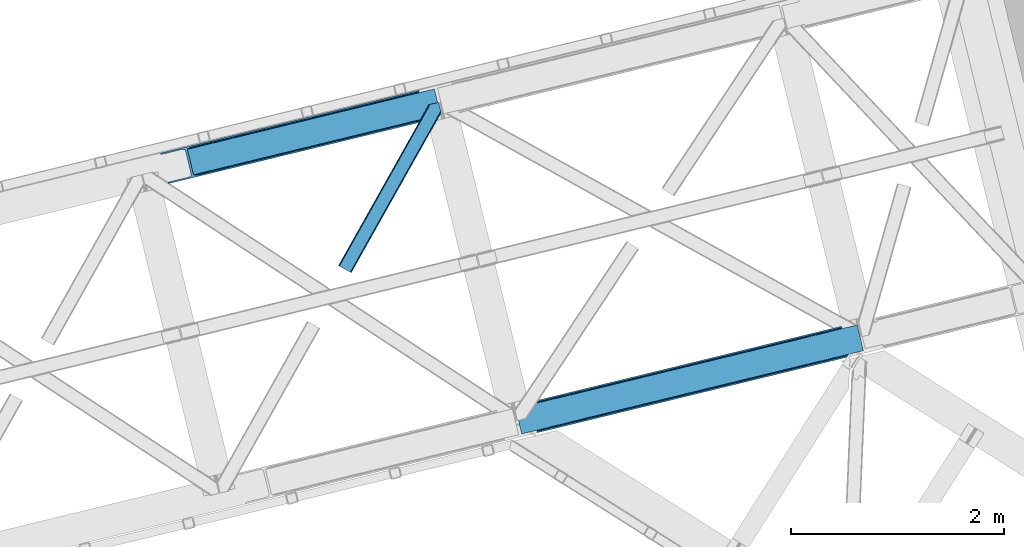
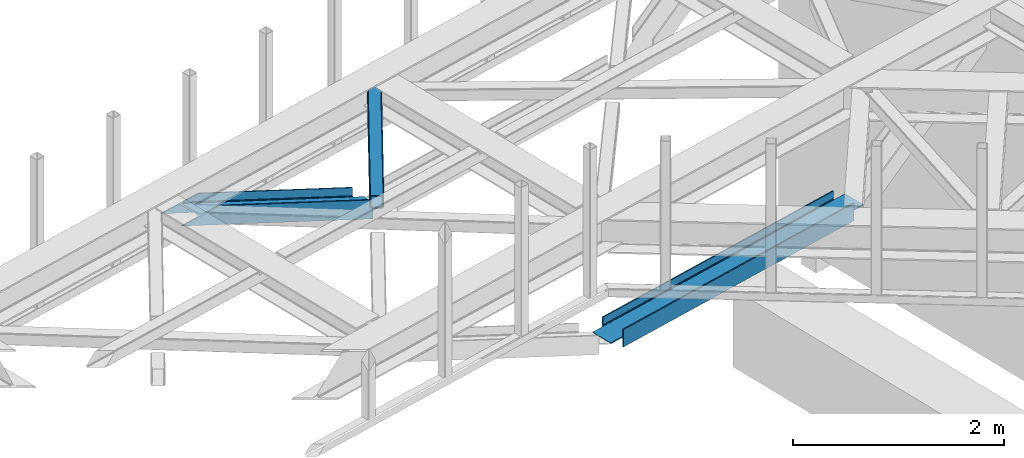
# One storey, part 57 of 67: 3 members.
"""IFC4 building model written with IfcOpenShell, lengths in millimetres."""

import ifcopenshell
import ifcopenshell.guid

model = None  # the IFC model being written
_history = None  # IfcOwnerHistory: only IFC2X3 demands one
_inside = {}  # id of a spatial element -> (the spatial element, [elements in it])
_under = {}  # id of a project, library or spatial element -> (it, [spatial elements below it])
_declared = {}  # id of a project -> (the project, [libraries it declares])
_typed = {}  # id of a type object -> (the type object, [elements of that type])
_made_of = {}  # id of a material, layer set ... -> (it, [elements and type objects made of it])


def new_model(schema):
    """Start an empty IFC model of exactly this schema.

    Asked for "IFC4X3", IfcOpenShell would pick the latest addendum, in which some entities
    have other attributes; the version numbers below select the first issue.
    IFC2X3 requires an IfcOwnerHistory on every rooted entity: one is made here for all.
    """
    global model, _history
    if schema == "IFC4X3":
        model = ifcopenshell.file(schema_version=(4, 3, 0, 0))
    else:
        model = ifcopenshell.file(schema=schema)
    _inside.clear()
    _under.clear()
    _declared.clear()
    _typed.clear()
    _made_of.clear()
    _history = None
    if model.schema == "IFC2X3":
        org = make("IfcOrganization", Name="unknown")
        user = make(
            "IfcPersonAndOrganization",
            ThePerson=make("IfcPerson", FamilyName="unknown"),
            TheOrganization=org,
        )
        app = make(
            "IfcApplication",
            ApplicationDeveloper=org,
            Version="unknown",
            ApplicationFullName="unknown",
            ApplicationIdentifier="unknown",
        )
        _history = make(
            "IfcOwnerHistory",
            OwningUser=user,
            OwningApplication=app,
            ChangeAction="ADDED",
            CreationDate=0,
        )
    return model


def make(cls, **values):
    """One entity of the class cls with the attributes given. An attribute that is None is left unset."""
    return model.create_entity(
        cls, **{name: value for name, value in values.items() if value is not None}
    )


def entity(cls, *values):
    """Any entity or typed value of the class cls, its attributes in the order of the schema. None: left unset."""
    e = model.create_entity(cls)
    for i, value in enumerate(values):
        if value is not None:
            e[i] = value
    return e


def rooted(cls, **values):
    """An entity with a GlobalId (a new one), such as an element, a storey or a relation."""
    return make(cls, GlobalId=ifcopenshell.guid.new(), OwnerHistory=_history, **values)


def si_unit(unit_type, name, prefix=None):
    """IfcSIUnit, for example si_unit("LENGTHUNIT", "METRE", prefix="MILLI")."""
    return make("IfcSIUnit", UnitType=unit_type, Prefix=prefix, Name=name)


def converted_unit(unit_type, name, factor, base, dimensions=None, offset=None):
    """IfcConversionBasedUnit, such as the inch: factor (a typed value) times the base unit."""
    return make(
        "IfcConversionBasedUnit"
        if offset is None
        else "IfcConversionBasedUnitWithOffset",
        ConversionOffset=offset,
        Dimensions=None
        if dimensions is None
        else entity("IfcDimensionalExponents", *dimensions),
        UnitType=unit_type,
        Name=name,
        ConversionFactor=make(
            "IfcMeasureWithUnit", ValueComponent=factor, UnitComponent=base
        ),
    )


def derived_unit(unit_type, elements):
    """IfcDerivedUnit: a product of units, each with its exponent."""
    return make(
        "IfcDerivedUnit",
        Elements=[
            make("IfcDerivedUnitElement", Unit=unit, Exponent=power)
            for unit, power in elements
        ],
        UnitType=unit_type,
    )


def assignment(units):
    """IfcUnitAssignment: the units of a project."""
    return None if units is None else make("IfcUnitAssignment", Units=units)


def point(xyz):
    """IfcCartesianPoint."""
    return None if xyz is None else make("IfcCartesianPoint", Coordinates=xyz)


def direction(xyz):
    """IfcDirection."""
    return None if xyz is None else make("IfcDirection", DirectionRatios=xyz)


def frame(location, z_axis=None, x_axis=None):
    """IfcAxis2Placement3D, a coordinate frame: its origin and axes. An axis left out is left unset."""
    return make(
        "IfcAxis2Placement3D",
        Location=point(location),
        Axis=direction(z_axis),
        RefDirection=direction(x_axis),
    )


def origin():
    """The frame at (0, 0, 0) with its axes left unset."""
    return frame((0.0, 0.0, 0.0))


def place(relative_to, where):
    """IfcLocalPlacement: puts the frame where relative to a parent placement (None: the world)."""
    return make(
        "IfcLocalPlacement", PlacementRelTo=relative_to, RelativePlacement=where
    )


def context(
    kind, dimensions, precision=None, world=None, true_north=None, identifier=None
):
    """IfcGeometricRepresentationContext, for example the 3D "Model" context."""
    return make(
        "IfcGeometricRepresentationContext",
        ContextIdentifier=identifier,
        ContextType=kind,
        CoordinateSpaceDimension=dimensions,
        Precision=precision,
        WorldCoordinateSystem=world,
        TrueNorth=true_north,
    )


def subcontext(parent, identifier, kind, view, scale=None):
    """IfcGeometricRepresentationSubContext, for example "Body" below "Model"."""
    return make(
        "IfcGeometricRepresentationSubContext",
        ContextIdentifier=identifier,
        ContextType=kind,
        ParentContext=parent,
        TargetScale=scale,
        TargetView=view,
    )


def project(units=None, contexts=None):
    """IfcProject with its units and contexts."""
    return rooted(
        "IfcProject",
        Name="project",
        RepresentationContexts=contexts,
        UnitsInContext=assignment(units),
    )


def spatial(cls, under=None, at=None, **own):
    """A site, building, storey or space (cls), placed at a placement, below another one or the project."""
    s = rooted(cls, ObjectPlacement=at, **own)
    if under is not None:
        _under.setdefault(under.id(), (under, []))[1].append(s)
    return s


def point_list(points):
    """IfcCartesianPointList2D or 3D."""
    cls = (
        "IfcCartesianPointList2D" if len(points[0]) == 2 else "IfcCartesianPointList3D"
    )
    return make(cls, CoordList=points)


def triangles(points, corners, closed=None, point_numbers=None):
    """IfcTriangulatedFaceSet: each triangle names its three corners, points numbered from 1."""
    return make(
        "IfcTriangulatedFaceSet",
        Coordinates=point_list(points),
        Closed=closed,
        CoordIndex=corners,
        PnIndex=point_numbers,
    )


def polygons(points, faces, closed=None, point_numbers=None):
    """IfcPolygonalFaceSet: a face is its outer loop, then its inner loops; points numbered from 1."""
    made = []
    for loops in faces:
        if len(loops) == 1:
            made.append(make("IfcIndexedPolygonalFace", CoordIndex=loops[0]))
        else:
            made.append(
                make(
                    "IfcIndexedPolygonalFaceWithVoids",
                    CoordIndex=loops[0],
                    InnerCoordIndices=loops[1:],
                )
            )
    return make(
        "IfcPolygonalFaceSet",
        Coordinates=point_list(points),
        Closed=closed,
        Faces=made,
        PnIndex=point_numbers,
    )


def shape(context_of_items, identifier, shape_type, items):
    """IfcShapeRepresentation: the items that make up one representation, for example the "Body"."""
    return make(
        "IfcShapeRepresentation",
        ContextOfItems=context_of_items,
        RepresentationIdentifier=identifier,
        RepresentationType=shape_type,
        Items=items,
    )


def made_of(thing, what):
    """Note that an element or type object is made of a material, layer set ...; save() writes the relation."""
    if what is not None:
        _made_of.setdefault(what.id(), (what, []))[1].append(thing)
    return thing


def type_object(cls, material=None, **own):
    """A type object (cls), such as IfcWallType, which elements share."""
    return made_of(rooted(cls, **own), material)


def element(
    cls,
    number,
    at=None,
    inside=None,
    cuts=None,
    type_object=None,
    material=None,
    context=None,
    identifier="Body",
    shape_type=None,
    held_by="IfcProductDefinitionShape",
    body=None,
    shapes=None,
    **own,
):
    """One element of the class cls, such as IfcWall. Its Tag is "e" and its number.

    at: its placement. inside: the storey or other place that contains it. cuts: it is an
    opening in that element (IfcRelVoidsElement). A single representation is given by context,
    identifier, shape_type and body (its items); several are given by shapes. held_by: the class
    of the entity that holds the representations. save() writes the other relations.
    """
    e = rooted(cls, Tag="e%d" % number, ObjectPlacement=at, **own)
    if body is not None:
        shapes = [shape(context, identifier, shape_type, body)]
    if shapes is not None:
        e.Representation = make(held_by, Representations=shapes)
    if inside is not None:
        _inside.setdefault(inside.id(), (inside, []))[1].append(e)
    if cuts is not None:
        rooted(
            "IfcRelVoidsElement", RelatingBuildingElement=cuts, RelatedOpeningElement=e
        )
    if type_object is not None:
        _typed.setdefault(type_object.id(), (type_object, []))[1].append(e)
    return made_of(e, material)


def aggregate(whole, parts):
    """IfcRelAggregates: a whole, such as a stair, and the parts it consists of."""
    return rooted("IfcRelAggregates", RelatingObject=whole, RelatedObjects=parts)


def save(model, path):
    """Write the relations noted so far, then the file.

    IfcRelAggregates (storeys below a building ...), IfcRelContainedInSpatialStructure (elements
    in a storey), IfcRelDefinesByType, IfcRelAssociatesMaterial and IfcRelDeclares: one each for
    every whole, place, type object, material and project.
    """
    for whole, parts in _under.values():
        aggregate(whole, parts)
    for where, things in _inside.values():
        rooted(
            "IfcRelContainedInSpatialStructure",
            RelatedElements=things,
            RelatingStructure=where,
        )
    for kind, things in _typed.values():
        rooted("IfcRelDefinesByType", RelatedObjects=things, RelatingType=kind)
    for what, things in _made_of.values():
        rooted("IfcRelAssociatesMaterial", RelatedObjects=things, RelatingMaterial=what)
    for by, libraries in _declared.values():
        rooted("IfcRelDeclares", RelatingContext=by, RelatedDefinitions=libraries)
    model.write(path)


model = new_model("IFC4")

# Units and contexts
model_context = context("Model", 3, precision=0.01, world=origin(), true_north=direction((6.12303176911189e-17, 1.0)))
plan_context = context("Plan", 3, precision=0.01, world=origin(), true_north=direction((6.12303176911189e-17, 1.0)))
body_context = subcontext(model_context, "Body", "Model", "MODEL_VIEW")
ifc_project = project(units=[si_unit("LENGTHUNIT", "METRE", prefix="MILLI"), si_unit("AREAUNIT", "SQUARE_METRE"), si_unit("VOLUMEUNIT", "CUBIC_METRE"), converted_unit("PLANEANGLEUNIT", "DEGREE", entity("IfcRatioMeasure", 0.0174532925199433), si_unit("PLANEANGLEUNIT", "RADIAN"), dimensions=[0, 0, 0, 0, 0, 0, 0]), si_unit("MASSUNIT", "GRAM", prefix="KILO"), derived_unit("MASSDENSITYUNIT", [(si_unit("MASSUNIT", "GRAM", prefix="KILO"), 1), (si_unit("LENGTHUNIT", "METRE"), -3)]), derived_unit("MOMENTOFINERTIAUNIT", [(si_unit("LENGTHUNIT", "METRE"), 4)]), si_unit("TIMEUNIT", "SECOND"), si_unit("FREQUENCYUNIT", "HERTZ"), si_unit("THERMODYNAMICTEMPERATUREUNIT", "DEGREE_CELSIUS"), derived_unit("THERMALTRANSMITTANCEUNIT", [(si_unit("MASSUNIT", "GRAM", prefix="KILO"), 1), (si_unit("THERMODYNAMICTEMPERATUREUNIT", "KELVIN"), -1), (si_unit("TIMEUNIT", "SECOND"), -3)]), derived_unit("VOLUMETRICFLOWRATEUNIT", [(si_unit("LENGTHUNIT", "METRE"), 3), (si_unit("TIMEUNIT", "SECOND"), -1)]), derived_unit("MASSFLOWRATEUNIT", [(si_unit("MASSUNIT", "GRAM", prefix="KILO"), 1), (si_unit("TIMEUNIT", "SECOND"), -1)]), derived_unit("ROTATIONALFREQUENCYUNIT", [(si_unit("TIMEUNIT", "SECOND"), -1)]), si_unit("ELECTRICCURRENTUNIT", "AMPERE"), si_unit("ELECTRICVOLTAGEUNIT", "VOLT"), si_unit("POWERUNIT", "WATT"), si_unit("FORCEUNIT", "NEWTON", prefix="KILO"), si_unit("ILLUMINANCEUNIT", "LUX"), si_unit("LUMINOUSFLUXUNIT", "LUMEN"), si_unit("LUMINOUSINTENSITYUNIT", "CANDELA"), derived_unit("USERDEFINED", [(si_unit("MASSUNIT", "GRAM", prefix="KILO"), -1), (si_unit("LENGTHUNIT", "METRE"), -2), (si_unit("TIMEUNIT", "SECOND"), 3), (si_unit("LUMINOUSFLUXUNIT", "LUMEN"), 1)]), derived_unit("LINEARVELOCITYUNIT", [(si_unit("LENGTHUNIT", "METRE"), 1), (si_unit("TIMEUNIT", "SECOND"), -1)]), si_unit("PRESSUREUNIT", "PASCAL"), derived_unit("USERDEFINED", [(si_unit("LENGTHUNIT", "METRE"), -2), (si_unit("MASSUNIT", "GRAM", prefix="KILO"), 1), (si_unit("TIMEUNIT", "SECOND"), -2)]), derived_unit("LINEARFORCEUNIT", [(si_unit("MASSUNIT", "GRAM", prefix="KILO"), 1), (si_unit("LENGTHUNIT", "METRE"), 1), (si_unit("TIMEUNIT", "SECOND"), -2), (si_unit("LENGTHUNIT", "METRE"), -1)]), derived_unit("PLANARFORCEUNIT", [(si_unit("MASSUNIT", "GRAM", prefix="KILO"), 1), (si_unit("LENGTHUNIT", "METRE"), 1), (si_unit("TIMEUNIT", "SECOND"), -2), (si_unit("LENGTHUNIT", "METRE"), -2)])], contexts=[model_context, plan_context])

# Site, building, storey
site_placement = place(None, origin())
site = spatial("IfcSite", under=ifc_project, at=site_placement, CompositionType="ELEMENT")
building_placement = place(site_placement, origin())
building = spatial("IfcBuilding", under=site, at=building_placement, CompositionType="ELEMENT")
storey_placement = place(building_placement, frame((0.0, 0.0, 19800.0)))
storey = spatial("IfcBuildingStorey", under=building, at=storey_placement, CompositionType="ELEMENT", Elevation=19800.0)

# Members
member_type_1 = type_object("IfcMemberType", PredefinedType="BRACE")
member_1_placement = place(storey_placement, frame((-5427.01065423434, 16164.9147625206, 2512.0)))
element("IfcMember", 1, at=member_1_placement, inside=storey, type_object=member_type_1, ObjectType="Steel Vertical Brace", PredefinedType="BRACE", context=body_context, shape_type="Tessellation", body=[
    polygons([(202.213006515028, 24.6242629021892, 77.7499999999953), (597.310843492559, 120.933540718262, 77.7499999999953), (1133.2837289006, 251.582602017929, 77.7499999999953), (1669.25661430864, 382.231663317597, 77.7499999999953), (2205.22949971669, 512.880724617267, 77.7499999999953), (2741.20238512474, 643.529785916936, 77.7499999999953), (3136.30022210225, 739.839063733, 77.7499999999953), (3136.30022210225, 739.839063733003, 0.0), (202.213006515024, 24.6242629021892, 0.0), (3139.37896131113, 727.208886977164, 0.0), (205.291745723898, 11.9940861463507, 0.0), (3139.37896131113, 727.208886977164, 199.999999999998), (205.291745723902, 11.9940861463507, 199.999999999998), (3136.30022210225, 739.839063733, 122.249999999994), (3136.30022210225, 739.839063733, 199.999999999998), (3135.97573046984, 741.170253676399, 84.6383017825712), (3135.0516564821, 744.961161904972, 90.4779220613573), (3133.93196117233, 749.554584314497, 93.8745154964792), (3133.93196117236, 749.554584314421, 106.125484503402), (3135.0516564821, 744.961161904972, 109.522077938641), (3135.97573046984, 741.170253676397, 115.361698217427), (202.213006515032, 24.6242629021914, 122.249999999994), (201.888514882617, 25.955452845588, 115.361698217427), (200.964440894882, 29.7463610741609, 109.522077938641), (199.844745585118, 34.3397834836339, 106.125484503441), (199.844745585125, 34.3397834836079, 93.8745154965962), (200.964440894883, 29.7463610741609, 90.4779220613573), (201.888514882618, 25.9554528455858, 84.6383017825712), (202.213006515032, 24.6242629021914, 199.999999999998), (2634.00780804312, 617.399973657001, 122.249999999994), (1990.84034555346, 460.6211000974, 122.249999999994), (1347.67288306381, 303.842226537796, 122.249999999994), (704.505420574163, 147.063352978195, 122.249999999994), (2738.57084504939, 654.325379189632, 94.3798315850377), (2736.93951545091, 661.017722963484, 95.7499999999999), (3272.91240085895, 791.666784263152, 95.7499999999999), (3274.54373045746, 784.974440489198, 94.3798315851979), (2202.59795964136, 523.676317889856, 94.3798315852023), (2200.96663004286, 530.368661663815, 95.7499999999999), (1666.62507423332, 393.027256590187, 94.3798315852023), (1664.99374463482, 399.719600364147, 95.7499999999999), (1130.65218882528, 262.378195290519, 94.3798315852023), (1129.02085922678, 269.07053906448, 95.7499999999999), (594.679303417238, 131.729133990851, 94.3798315852023), (593.047973818733, 138.421477764808, 95.7499999999999), (58.7064180091808, 1.08007269117741, 94.3798315852023), (57.0750884106749, 7.77241646513577, 95.7499999999999), (2203.98093409654, 518.002822789238, 90.4779220613573), (2739.95381950459, 648.65188408891, 90.4779220613573), (1668.00804868849, 387.353761489571, 90.4779220613573), (1132.03516328045, 256.704700189901, 90.4779220613573), (596.062277872436, 126.055638890127, 90.4779220615175), (2204.90500808427, 514.211914560663, 84.6383017825712), (2740.87789349232, 644.860975860335, 84.6383017825712), (1668.93212267623, 383.562853260996, 84.6383017825712), (1132.95923726819, 252.913791961326, 84.6383017825712), (596.986351860144, 122.264730661659, 84.6383017825712), (58.9696971545974, 6.49720277579036e-12, 93.8745154965962), (3274.80700960288, 783.894367798021, 93.8745154965962), (1990.51585392106, 461.952290040796, 115.361698217427), (2633.68331641071, 618.7311636004, 115.361698217427), (1347.34839143141, 305.173416481193, 115.361698217427), (704.180928941748, 148.394542921592, 115.361698217427), (1989.59177993332, 465.743198269371, 109.522077938641), (2632.75924242298, 622.522071828933, 109.522077938576), (1346.42431744367, 308.964324709768, 109.522077938641), (703.256854954014, 152.185451150165, 109.522077938641), (1988.20880547815, 471.416693369991, 105.620168414796), (2631.3762679678, 628.195566929592, 105.620168414796), (1345.0413429885, 314.637819810388, 105.620168414796), (701.873880498833, 157.858946250822, 105.620168414861), (2629.7449383693, 634.887910703551, 104.249999999998), (3274.54373045746, 784.974440489196, 105.620168414796), (3272.91240085896, 791.666784263154, 104.249999999998), (1986.57747587964, 478.109037143948, 104.249999999998), (1343.41001338999, 321.330163584342, 104.249999999998), (700.242550900337, 164.551290024741, 104.249999999998), (57.0750884106727, 7.77241646513577, 104.249999999998), (58.7064180091862, 1.08007269117957, 105.6201684148), (3274.80700960287, 783.894367798023, 106.125484503402), (58.9696971545974, 0.0, 106.125484503397), (3217.73192119221, 1018.03841381011, 95.7499999999999), (3216.10059159371, 1024.73075758407, 94.3798315852023), (3215.83731244829, 1025.81083027525, 93.8745154965962), (3215.83731244829, 1025.81083027525, 106.125484503397), (3216.10059159371, 1024.73075758407, 105.620168414796), (3217.73192119221, 1018.03841381011, 104.250000000002), (1.8946087439236, 234.144046012098, 104.250000000002), (0.263279145419858, 240.836389786054, 105.620168414796), (1.08286712929839e-12, 241.916462477229, 106.125484503402), (1.08286712929839e-12, 241.916462477229, 93.8745154965962), (0.263279145423107, 240.836389786054, 94.3798315852023), (1.8946087439236, 234.144046012098, 95.7499999999999), (645.062071233588, 390.922919571701, 95.7499999999999), (1288.22953372324, 547.701793131306, 95.7499999999999), (1931.39699621289, 704.480666690907, 95.7499999999999), (2574.56445870255, 861.25954025051, 95.7499999999999), (2681.75903578416, 887.389352510444, 104.250000000002), (2145.78615037611, 756.740291210774, 104.250000000002), (1609.81326496807, 626.091229911109, 104.250000000002), (1073.84037956003, 495.442168611439, 104.250000000002), (537.867494151985, 364.793107311772, 104.250000000002), (1927.45861817149, 720.637413794061, 84.6383017825712), (1927.13412653906, 721.968603737453, 77.7499999999953), (2570.30158902872, 878.747477297058, 77.7499999999953), (2570.62608066114, 877.416287353662, 84.6383017825712), (1284.29115568184, 563.858540234457, 84.6383017825712), (1283.96666404941, 565.189730177852, 77.7499999999953), (641.123693192178, 407.079666674852, 84.6383017825712), (640.799201559762, 408.410856618251, 77.7499999999953), (1928.38269215922, 716.846505565488, 90.4779220613573), (2571.55015464886, 873.625379125128, 90.4779220614179), (1285.21522966957, 560.067632005882, 90.4779220613573), (642.047767179912, 403.288758446281, 90.4779220613573), (1929.76566661439, 711.173010464863, 94.3798315852023), (2572.93312910404, 867.951884024469, 94.3798315852023), (1286.59820412474, 554.394136905262, 94.3798315852023), (643.430741635094, 397.61526334562, 94.3798315851416), (3072.59400308785, 1001.18656737306, 77.7499999999953), (3072.91849472027, 999.855377429661, 84.6383017825712), (3073.84256870799, 996.064469201149, 90.4779220614439), (3074.96226401778, 991.471046791611, 93.8745154965442), (139.755353120758, 280.849668370336, 90.4779220614439), (138.831279133036, 284.64057659885, 84.6383017825712), (138.506787500626, 285.971766542247, 77.7499999999953), (140.875048430543, 276.256245960772, 93.8745154965052), (2680.12770618568, 894.081696284298, 105.620168414956), (2144.15482077761, 763.432634984735, 105.620168414796), (1608.18193536956, 632.783573685067, 105.620168414796), (1072.20904996152, 502.134512385398, 105.620168414796), (536.23616455348, 371.48545108573, 105.620168414796), (2142.77184632243, 769.106130085353, 109.522077938641), (2678.74473173048, 899.755191385027, 109.522077938641), (1606.79896091439, 638.457068785685, 109.522077938641), (1070.82607550635, 507.808007486015, 109.522077938641), (534.853190098281, 377.158946186456, 109.522077938476), (2141.8477723347, 772.897038313926, 115.361698217427), (2677.82065774275, 903.546099613597, 115.361698217427), (1605.87488692666, 642.247977014258, 115.361698217427), (1069.90200151862, 511.598915714588, 115.361698217427), (533.929116110574, 380.949854414921, 115.361698217427), (2141.52328070228, 774.22822825732, 122.249999999994), (2677.49616611034, 904.877289556992, 122.249999999994), (1605.55039529424, 643.579166957652, 122.249999999994), (1069.5775098862, 512.930105657983, 122.249999999994), (533.604624478158, 382.281044358315, 122.249999999994), (3073.84256870796, 996.064469201247, 109.522077938415), (3072.91849472027, 999.855377429664, 115.361698217427), (3072.59400308785, 1001.18656737306, 122.249999999994), (138.50678750063, 285.971766542247, 122.249999999994), (138.831279133041, 284.64057659885, 115.361698217427), (139.755353120736, 280.849668370433, 109.522077938415), (140.875048430552, 276.256245960739, 106.125484503536), (3074.9622640178, 991.471046791488, 106.125484503623), (3072.59400308785, 1001.18656737306, 0.0), (3069.51526387898, 1013.8167441289, 0.0), (3069.51526387898, 1013.8167441289, 199.999999999998), (3072.59400308785, 1001.18656737306, 199.999999999998), (138.506787500632, 285.971766542247, 199.999999999998), (135.428048291757, 298.601943298085, 199.999999999998), (135.428048291757, 298.601943298085, 0.0), (138.506787500632, 285.971766542247, 0.0)], [[[1, 2, 3, 4, 5, 6, 7, 8, 9]], [[9, 8, 10, 11]], [[11, 10, 12, 13]], [[14, 15, 12, 10, 8, 7, 16, 17, 18, 19, 20, 21]], [[22, 23, 24, 25, 26, 27, 28, 1, 9, 11, 13, 29]], [[13, 12, 15, 29]], [[29, 15, 14, 30, 31, 32, 33, 22]], [[34, 35, 36, 37]], [[38, 39, 35, 34]], [[40, 41, 39, 38]], [[42, 43, 41, 40]], [[44, 45, 43, 42]], [[46, 47, 45, 44]], [[48, 38, 34, 49]], [[50, 40, 38, 48]], [[51, 42, 40, 50]], [[52, 44, 42, 51]], [[53, 48, 49, 54]], [[55, 50, 48, 53]], [[56, 51, 50, 55]], [[57, 52, 51, 56]], [[5, 53, 54, 6]], [[4, 55, 53, 5]], [[3, 56, 55, 4]], [[2, 57, 56, 3]], [[17, 16, 54, 49]], [[16, 7, 6, 54]], [[1, 28, 57, 2]], [[28, 27, 52, 57]], [[44, 26, 58, 46]], [[52, 26, 44]], [[26, 52, 27]], [[18, 37, 59]], [[49, 18, 17]], [[34, 18, 49]], [[18, 34, 37]], [[60, 31, 30, 61]], [[62, 32, 31, 60]], [[63, 33, 32, 62]], [[64, 60, 61, 65]], [[66, 62, 60, 64]], [[67, 63, 62, 66]], [[68, 64, 65, 69]], [[70, 66, 64, 68]], [[71, 67, 66, 70]], [[72, 69, 73, 74]], [[75, 68, 69, 72]], [[76, 70, 68, 75]], [[77, 71, 70, 76]], [[78, 79, 71, 77]], [[14, 21, 61, 30]], [[21, 20, 65, 61]], [[69, 19, 80, 73]], [[24, 23, 63, 67]], [[23, 22, 33, 63]], [[25, 79, 81]], [[67, 25, 24]], [[71, 25, 67]], [[25, 71, 79]], [[65, 19, 69]], [[19, 65, 20]], [[19, 18, 59, 80]], [[25, 81, 58, 26]], [[74, 73, 80, 59, 37, 36, 82, 83, 84, 85, 86, 87]], [[47, 46, 58, 81, 79, 78, 88, 89, 90, 91, 92, 93]], [[47, 93, 94, 95, 96, 97, 82, 36, 35, 39, 41, 43, 45]], [[88, 78, 77, 76, 75, 72, 74, 87, 98, 99, 100, 101, 102]], [[103, 104, 105, 106]], [[107, 108, 104, 103]], [[109, 110, 108, 107]], [[111, 103, 106, 112]], [[113, 107, 103, 111]], [[114, 109, 107, 113]], [[115, 111, 112, 116]], [[117, 113, 111, 115]], [[118, 114, 113, 117]], [[97, 116, 83, 82]], [[96, 115, 116, 97]], [[95, 117, 115, 96]], [[94, 118, 117, 95]], [[93, 92, 118, 94]], [[119, 120, 106, 105]], [[120, 121, 112, 106]], [[116, 122, 84, 83]], [[123, 124, 109, 114]], [[124, 125, 110, 109]], [[126, 92, 91]], [[114, 126, 123]], [[118, 126, 114]], [[126, 118, 92]], [[112, 122, 116]], [[122, 112, 121]], [[127, 98, 87, 86]], [[128, 99, 98, 127]], [[129, 100, 99, 128]], [[130, 101, 100, 129]], [[131, 102, 101, 130]], [[89, 88, 102, 131]], [[132, 128, 127, 133]], [[134, 129, 128, 132]], [[135, 130, 129, 134]], [[136, 131, 130, 135]], [[137, 132, 133, 138]], [[139, 134, 132, 137]], [[140, 135, 134, 139]], [[141, 136, 135, 140]], [[142, 137, 138, 143]], [[144, 139, 137, 142]], [[145, 140, 139, 144]], [[146, 141, 140, 145]], [[147, 148, 138, 133]], [[148, 149, 143, 138]], [[150, 151, 141, 146]], [[151, 152, 136, 141]], [[131, 153, 90, 89]], [[136, 153, 131]], [[153, 136, 152]], [[154, 86, 85]], [[133, 154, 147]], [[127, 154, 133]], [[154, 127, 86]], [[85, 84, 122, 154]], [[90, 153, 126, 91]], [[154, 122, 121, 120, 119, 155, 156, 157, 158, 149, 148, 147]], [[153, 152, 151, 150, 159, 160, 161, 162, 125, 124, 123, 126]], [[162, 155, 119, 105, 104, 108, 110, 125]], [[161, 156, 155, 162]], [[150, 146, 145, 144, 142, 143, 149, 158, 159]], [[159, 158, 157, 160]], [[160, 157, 156, 161]]], closed=True),
])
member_type_2 = type_object("IfcMemberType", PredefinedType="BRACE")
member_2_placement = place(storey_placement, frame((-8767.28345947266, 18520.4404632568, 2584.39182128906)))
element("IfcMember", 2, at=member_2_placement, inside=storey, type_object=member_type_2, ObjectType="Steel Vertical Brace", PredefinedType="BRACE", context=body_context, shape_type="Tessellation", body=[
    triangles([(2635.93561706543, 649.181304931641, 33.9583923339851), (2634.040965271, 656.952923583984, 33.9583923339851), (2635.12578277588, 650.127758789062, 32.7096313476541), (2635.1856628418, 648.998757934569, 32.2491943359382), (2635.93561706543, 649.181304931641, 45.3390930175774), (2495.05991363525, 614.841540527344, 97.2405761718728), (2495.05991363525, 614.841540527344, 110.67696533203), (2634.040965271, 656.952923583984, 43.2810791015618), (309.064274597169, 90.2154235839844, 1121.6082824707), (313.935488891602, 84.3134582519524, 1121.6082824707), (2635.65947113037, 650.313793945312, 45.0391113281257), (324.545306396485, 80.8892486572258, 1121.6082824707), (2496.17961273193, 610.247634887695, 114.402319335935), (2497.10397491455, 606.457168579102, 120.806579589844), (339.278128051759, 80.4636932373032, 1121.6082824707), (2497.42837371826, 605.125854492188, 128.361932373045), (355.89223022461, 83.1030670166001, 1121.6082824707), (2497.42837371826, 605.125854492188, 213.642773437499), (539.761820983887, 127.923587036134, 1121.6082824707), (2500.5072555542, 592.495230102541, 213.642773437499), (542.840702819825, 115.29412536621, 1121.6082824707), (2578.86061248779, 883.325152587891, 43.2810791015618), (253.883921813966, 316.587652587892, 1121.6082824707), (2500.5072555542, 592.495230102541, 2.47891845702907), (2497.42837371826, 605.125854492188, 79.5532836914063), (2497.42837371826, 605.125854492188, 2.47891845702907), (2497.10397491455, 606.457168579102, 87.1086364746079), (2496.17961273193, 610.247634887695, 93.5152221679673), (287.352809143067, 77.833621215821, 1121.6082824707), (279.509101867676, 69.9108489990249, 1121.6082824707), (288.961431884767, 85.3157226562507, 1121.6082824707), (266.619772338869, 62.7531463623054, 1121.6082824707), (250.655049133302, 57.4511444091804, 1121.6082824707), (2488.16672973633, 589.487274169922, 0.0), (69.8637588500987, 0.0, 1121.6082824707), (2485.08784790039, 602.117898559569, 0.0), (66.7848770141609, 12.630624389647, 1121.6082824707), (2578.86061248779, 883.325152587891, 33.9583923339851), (233.781079101564, 311.686788940431, 1121.6082824707), (2576.96596069336, 891.097933959962, 33.9583923339851), (2577.24210662842, 889.964282226563, 45.0391113281257), (2576.96596069336, 891.097933959962, 45.3390930175774), (2576.68225708008, 889.884054565431, 32.7096313476541), (2576.21600646973, 890.914224243163, 32.2491943359382), (2436.09025726318, 856.758169555666, 97.2405761718728), (2436.09025726318, 856.758169555666, 110.67696533203), (255.492544555666, 324.069754028322, 1121.6082824707), (263.336251831055, 331.992526245118, 1121.6082824707), (2434.9705581665, 861.350912475587, 114.402319335935), (2434.04677734375, 865.141378784181, 120.806579589844), (276.220930480958, 339.14906616211, 1121.6082824707), (2433.72237854004, 866.472692871095, 128.361932373045), (292.186235046387, 344.451068115235, 1121.6082824707), (2434.9705581665, 861.350912475587, 93.5152221679673), (228.90986480713, 317.589916992187, 1121.6082824707), (218.300047302248, 321.014126586913, 1121.6082824707), (2433.72237854004, 866.472692871095, 79.5532836914063), (2434.04677734375, 865.141378784181, 87.1086364746079), (203.562574768068, 321.437356567381, 1121.6082824707), (186.948472595215, 318.797982788084, 1121.6082824707), (2433.72237854004, 866.472692871095, 213.642773437499), (476.055825805664, 389.271588134765, 1121.6082824707), (2430.6434967041, 879.103317260742, 213.642773437499), (472.976943969727, 401.901049804688, 1121.6082824707), (0.0, 286.608087158202, 1121.6082824707), (3.07888183593786, 273.978625488282, 1121.6082824707), (2430.6434967041, 879.103317260742, 2.47891845702907), (2433.72237854004, 866.472692871095, 2.47891845702907), (2418.30297088623, 876.095361328124, 0.0), (2421.38185272217, 863.464736938477, 0.0)], [[1, 2, 3], [3, 4, 1], [4, 5, 6], [5, 4, 1], [7, 6, 5], [8, 9, 10], [11, 10, 7], [7, 10, 12], [12, 13, 7], [7, 5, 11], [14, 13, 15], [12, 15, 13], [16, 14, 17], [15, 17, 14], [10, 11, 8], [18, 16, 19], [17, 19, 16], [20, 18, 19], [19, 21, 20], [8, 22, 23], [23, 9, 8], [24, 25, 16], [26, 25, 24], [16, 25, 14], [16, 20, 24], [18, 20, 16], [14, 25, 27], [27, 28, 13], [28, 6, 13], [7, 13, 6], [13, 14, 27], [29, 3, 6], [6, 30, 29], [6, 28, 30], [3, 4, 6], [2, 3, 31], [29, 31, 3], [28, 27, 30], [32, 30, 27], [27, 25, 32], [33, 32, 25], [34, 20, 21], [20, 34, 24], [21, 35, 34], [25, 36, 33], [25, 26, 36], [37, 33, 36], [36, 34, 35], [35, 37, 36], [26, 24, 36], [34, 36, 24], [38, 2, 39], [31, 39, 2], [22, 38, 8], [40, 22, 41], [22, 40, 38], [41, 42, 40], [2, 8, 38], [8, 1, 11], [1, 8, 2], [5, 11, 1], [38, 40, 43], [44, 43, 40], [42, 44, 45], [42, 40, 44], [45, 46, 42], [47, 41, 46], [46, 48, 47], [46, 49, 48], [41, 42, 46], [22, 41, 47], [47, 23, 22], [49, 50, 51], [51, 48, 49], [50, 52, 53], [53, 51, 50], [54, 45, 55], [55, 56, 54], [57, 58, 59], [59, 60, 57], [58, 54, 56], [56, 59, 58], [44, 43, 45], [55, 45, 43], [43, 38, 39], [39, 55, 43], [52, 61, 62], [62, 53, 52], [61, 63, 62], [64, 62, 63], [9, 23, 31], [48, 51, 59], [53, 64, 65], [62, 64, 53], [51, 53, 60], [23, 47, 55], [47, 48, 56], [12, 32, 15], [21, 17, 35], [17, 15, 33], [21, 19, 17], [12, 10, 30], [10, 9, 29], [31, 23, 39], [60, 59, 51], [55, 47, 56], [59, 56, 48], [55, 39, 23], [65, 60, 53], [65, 66, 60], [33, 15, 32], [30, 10, 29], [31, 29, 9], [30, 32, 12], [33, 35, 17], [35, 33, 37], [50, 58, 57], [45, 54, 49], [54, 58, 49], [50, 49, 58], [49, 46, 45], [57, 67, 52], [67, 57, 68], [63, 52, 67], [57, 52, 50], [63, 61, 52], [63, 69, 64], [63, 67, 69], [65, 64, 69], [70, 57, 60], [57, 70, 68], [60, 66, 70], [69, 70, 66], [66, 65, 69], [67, 68, 70], [70, 69, 67]]),
])
member_type_3 = type_object("IfcMemberType", PredefinedType="BRACE")
member_3_placement = place(storey_placement, frame((-7093.94780731201, 17681.0521636963, 3822.99993896484)))
element("IfcMember", 3, at=member_3_placement, inside=storey, type_object=member_type_3, ObjectType="Steel Horizontal Brace", PredefinedType="BRACE", context=body_context, shape_type="Tessellation", body=[
    triangles([(963.930697631836, 1521.10947875976, 138.668280029298), (961.605839538574, 1530.64726867676, 140.00075683594), (106.81092224121, 8.56924438476563, 140.00075683594), (112.646612548828, 5.28921203613208, 138.668280029298), (965.901507568359, 1513.02392578125, 134.87548828125), (117.598635864258, 2.50914916992042, 134.87548828125), (967.218287658691, 1507.62192993164, 129.196765136719), (120.904829406738, 0.651123046875, 129.196765136719), (967.681050109863, 1505.72553405762, 122.499499511719), (122.068711853027, 0.0, 122.499499511719), (967.681050109863, 1505.72553405762, 17.5012573242202), (122.068711853027, 0.0, 17.5012573242202), (15.2577896118164, 59.9835479736321, 140.00075683594), (873.405990600586, 1588.02516174316, 140.00075683594), (943.45694732666, 1605.10086364746, 140.00075683594), (851.920092773437, 1582.787109375, 129.196765136719), (850.14868927002, 1582.35574035644, 122.499499511719), (1.15981292724609, 67.8993438720681, 129.196765136719), (0.0, 68.5527923583977, 122.499499511719), (856.962808227539, 1584.0172668457, 134.87548828125), (4.47007598876917, 66.04248046875, 134.87548828125), (864.504208374024, 1585.8555267334, 138.668280029298), (9.41802978515625, 63.2624176025383, 138.668280029298), (850.14868927002, 1582.35574035644, 17.5012573242202), (0.0, 68.5527923583977, 17.5012573242202), (1.15981292724609, 67.8993438720681, 10.8039916992202), (851.920092773437, 1582.787109375, 10.8039916992202), (810.913293457031, 1502.80361938477, 5.52059326172093), (4.47007598876917, 66.04248046875, 5.12526855468968), (810.772023010254, 1501.75252075195, 5.13457031250073), (856.451792907715, 1583.89285583496, 5.52059326172093), (810.640054321289, 1500.7432800293, 4.76482543945531), (810.549362182617, 1500.07355346679, 4.52065429687718), (9.41802978515625, 63.2624176025383, 1.33247680664135), (812.299255371094, 1492.894921875, 1.33247680664135), (814.624113464355, 1483.35829467773, 0.0), (15.2577896118164, 59.9835479736321, 0.0), (842.022441101074, 1370.95817871093, 0.0), (106.81092224121, 8.56924438476563, 0.0), (876.666256713867, 1379.40301208496, 0.0), (893.620454406738, 1383.53648071289, 5.52059326172093), (885.56803894043, 1381.57264709473, 1.33247680664135), (842.993893432617, 1371.19537353516, 5.52059326172093), (842.022441101074, 1370.95817871093, 4.52065429687718), (117.598635864258, 2.50914916992042, 5.12526855468968), (112.646612548828, 5.28921203613208, 1.33247680664135), (966.000920104981, 1506.03830566406, 10.9621215820334), (120.904829406738, 0.651123046875, 10.8039916992202), (967.429902648925, 1506.75570373535, 12.5201660156272), (961.010527038574, 1503.53380737305, 5.52059326172093), (936.65678100586, 1603.44282531738, 5.52059326172093), (963.604554748535, 1522.44893188476, 12.5201660156272), (958.492657470703, 1525.72547607422, 8.3320495605476), (955.213787841797, 1533.55988159179, 6.99957275390625), (938.093321228027, 1603.79280395508, 6.99957275390625), (21.3638122558596, 56.5558502197237, 6.99957275390625), (882.70484161377, 1590.29130249023, 6.99957275390625), (100.704899597168, 11.9957794189431, 6.99957275390625), (111.497264099121, 5.9380096435525, 12.1248413085959), (114.803457641601, 4.07998352050708, 17.8035644531265), (964.788784790039, 1517.59108886719, 17.8035644531265), (106.544659423828, 8.71690979003688, 8.3320495605476), (965.250965881348, 1515.69353027343, 24.5008300781265), (115.962689208985, 3.4265350341775, 24.5008300781265), (965.250965881348, 1515.69353027343, 115.499926757813), (115.962689208985, 3.4265350341775, 115.499926757813), (964.788784790039, 1517.59108886719, 122.197192382813), (963.472004699707, 1522.9930847168, 127.873590087893), (961.50061340332, 1531.07863769531, 131.668707275392), (959.176336669922, 1540.61526489258, 133.001184082033), (943.45694732666, 1605.10086364746, 133.001184082033), (114.803457641601, 4.07998352050708, 122.197192382813), (111.497264099121, 5.9380096435525, 127.873590087893), (106.544659423828, 8.71690979003688, 131.668707275392), (100.704899597168, 11.9957794189431, 133.001184082033), (21.3638122558596, 56.5558502197237, 133.001184082033), (882.70484161377, 1590.29130249023, 133.001184082033), (10.5714477539059, 62.6147827148416, 127.873590087893), (15.5240524291994, 59.8347198486299, 131.668707275392), (6.10137176513672, 65.1239318847656, 115.499926757813), (7.2652542114256, 64.4728088378906, 122.197192382813), (10.5714477539059, 62.6147827148416, 12.1248413085959), (15.5240524291994, 59.8347198486299, 8.3320495605476), (6.10137176513672, 65.1239318847656, 24.5008300781265), (7.2652542114256, 64.4728088378906, 17.8035644531265), (873.807710266113, 1588.12283020019, 131.668707275392), (866.261659240722, 1586.28340759277, 127.873590087893), (861.223594665527, 1585.05557556152, 122.197192382813), (859.45219116211, 1584.62420654297, 115.499926757813), (873.807710266113, 1588.12283020019, 8.3320495605476), (861.223594665527, 1585.05557556152, 17.8035644531265), (866.261659240722, 1586.28340759277, 12.1248413085959), (859.45219116211, 1584.62420654297, 24.5008300781265)], [[1, 2, 3], [3, 4, 1], [5, 1, 4], [4, 6, 5], [7, 5, 6], [6, 8, 7], [9, 7, 8], [8, 10, 9], [11, 9, 12], [10, 12, 9], [13, 2, 14], [13, 3, 2], [2, 15, 14], [16, 17, 18], [19, 18, 17], [20, 16, 21], [18, 21, 16], [22, 20, 23], [21, 23, 20], [14, 22, 13], [23, 13, 22], [17, 24, 19], [25, 19, 24], [26, 27, 28], [28, 29, 26], [28, 30, 29], [27, 31, 28], [29, 30, 32], [33, 34, 29], [33, 35, 34], [35, 36, 34], [37, 34, 36], [24, 27, 26], [26, 25, 24], [38, 37, 36], [39, 38, 40], [38, 39, 37], [40, 41, 42], [40, 38, 43], [40, 43, 41], [43, 38, 44], [36, 33, 44], [36, 35, 33], [44, 38, 36], [45, 46, 42], [47, 48, 41], [48, 45, 41], [12, 48, 47], [47, 49, 12], [49, 11, 12], [41, 50, 47], [42, 41, 45], [40, 42, 46], [46, 39, 40], [41, 28, 50], [41, 43, 28], [31, 50, 28], [51, 50, 31], [52, 50, 53], [49, 47, 52], [52, 47, 50], [54, 50, 51], [50, 54, 53], [51, 55, 54], [56, 54, 57], [56, 58, 54], [54, 55, 57], [59, 60, 61], [61, 52, 59], [62, 59, 52], [53, 54, 58], [58, 62, 53], [52, 53, 62], [63, 61, 60], [60, 64, 63], [65, 63, 64], [64, 66, 65], [61, 49, 52], [9, 11, 63], [11, 61, 63], [63, 65, 9], [11, 49, 61], [67, 9, 65], [7, 9, 67], [5, 67, 68], [67, 5, 7], [68, 1, 5], [69, 1, 68], [69, 70, 2], [69, 2, 1], [70, 15, 2], [70, 71, 15], [67, 65, 72], [66, 72, 65], [68, 67, 73], [72, 73, 67], [69, 68, 74], [73, 74, 68], [70, 69, 75], [74, 75, 69], [76, 70, 75], [70, 76, 77], [71, 70, 77], [8, 73, 72], [66, 12, 10], [8, 72, 10], [8, 6, 73], [72, 66, 10], [73, 6, 4], [75, 3, 13], [3, 74, 4], [74, 3, 75], [74, 73, 4], [48, 59, 45], [64, 12, 66], [12, 60, 48], [60, 12, 64], [48, 60, 59], [39, 58, 37], [46, 45, 59], [59, 62, 46], [62, 58, 39], [39, 46, 62], [78, 23, 21], [13, 76, 75], [13, 79, 76], [79, 13, 23], [78, 79, 23], [80, 19, 25], [18, 81, 78], [21, 18, 78], [81, 18, 19], [80, 81, 19], [34, 82, 29], [37, 58, 56], [56, 83, 37], [83, 82, 34], [34, 37, 83], [26, 29, 82], [25, 84, 80], [85, 25, 26], [25, 85, 84], [85, 26, 82], [22, 14, 86], [15, 77, 14], [77, 15, 71], [77, 86, 14], [87, 22, 86], [87, 20, 22], [20, 88, 16], [88, 20, 87], [17, 88, 89], [88, 17, 16], [57, 31, 90], [91, 92, 31], [92, 90, 31], [57, 51, 31], [51, 57, 55], [93, 91, 24], [27, 24, 91], [17, 93, 24], [93, 17, 89], [91, 31, 27], [91, 93, 85], [84, 85, 93], [92, 91, 82], [85, 82, 91], [90, 92, 83], [82, 83, 92], [57, 90, 56], [83, 56, 90], [93, 89, 84], [80, 84, 89], [86, 77, 76], [76, 79, 86], [87, 86, 79], [79, 78, 87], [88, 87, 78], [78, 81, 88], [89, 88, 81], [81, 80, 89]]),
])

save(model, "model.ifc")
